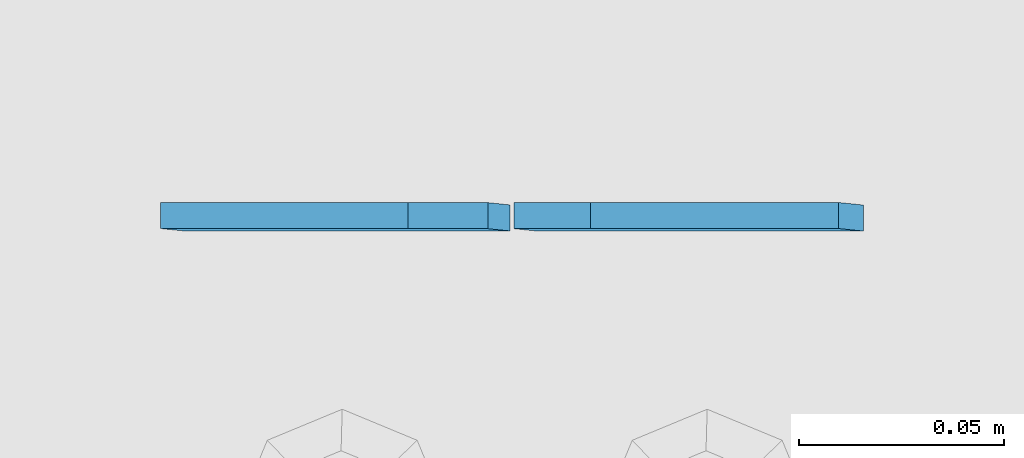
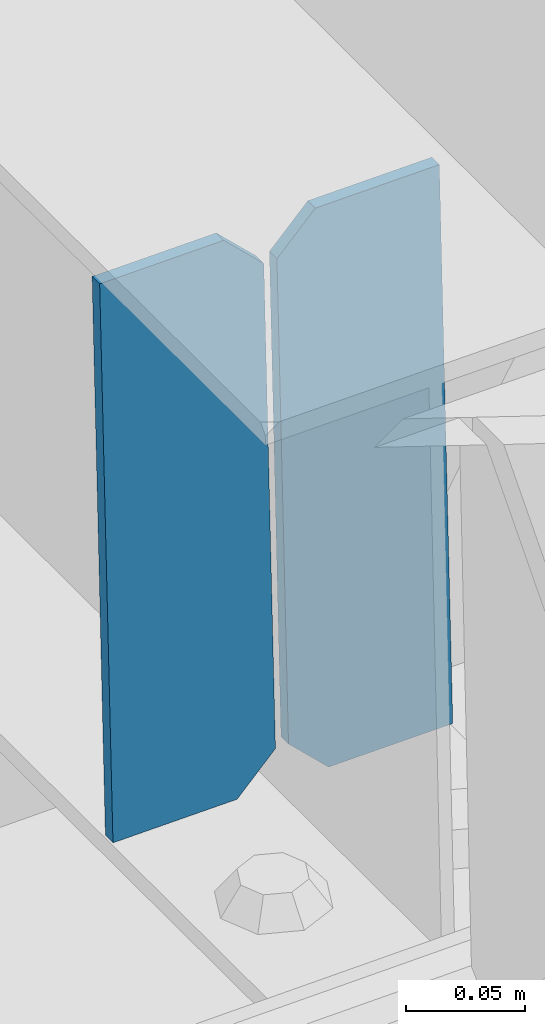
# One storey, part 3375 of 3843: 2 plates, 1 element without a shape of its own.
"""IFC2X3 building model written with IfcOpenShell, lengths in millimetres."""

from ifc_helpers import new_model, si_unit, frame, origin_with_axes, place, context, subcontext, project, spatial, faceted_brep, material, type_object, element, aggregate, save


model = new_model("IFC2X3")

# Units and contexts
model_context = context("Model", 3, precision=1e-05, world=origin_with_axes())
body_context = subcontext(model_context, "Body", "Model", "MODEL_VIEW")
ifc_project = project(units=[si_unit("LENGTHUNIT", "METRE", prefix="MILLI"), si_unit("AREAUNIT", "SQUARE_METRE"), si_unit("VOLUMEUNIT", "CUBIC_METRE"), si_unit("MASSUNIT", "GRAM", prefix="KILO"), si_unit("TIMEUNIT", "SECOND"), si_unit("PLANEANGLEUNIT", "RADIAN"), si_unit("SOLIDANGLEUNIT", "STERADIAN"), si_unit("THERMODYNAMICTEMPERATUREUNIT", "DEGREE_CELSIUS"), si_unit("LUMINOUSINTENSITYUNIT", "LUMEN")], contexts=[model_context])

# Site, building, storey
site_placement = place(None, origin_with_axes())
site = spatial("IfcSite", under=ifc_project, at=site_placement, CompositionType="ELEMENT")
building_placement = place(site_placement, origin_with_axes())
building = spatial("IfcBuilding", under=site, at=building_placement, Name="Undefined", CompositionType="ELEMENT")
storey_placement = place(building_placement, origin_with_axes())
storey = spatial("IfcBuildingStorey", under=building, at=storey_placement, Name="Undefined", CompositionType="ELEMENT", Elevation=0.0)

# Assembly, plates
assembly_placement = place(storey_placement, origin_with_axes())
assembly = element("IfcElementAssembly", 1, at=assembly_placement, inside=storey, Name="BEAM", AssemblyPlace="NOTDEFINED", PredefinedType="RIGID_FRAME")
ifc_material = material(Name="STEEL/A572-50")
plate_type = type_object("IfcPlateType", PredefinedType="NOTDEFINED")
plate_1_placement = place(assembly_placement, frame((40773.0964783088, 75783.4289593356, 45538.0196245364), z_axis=(-0.0211520975252424, 0.00216334199957782, 0.999773928806746), x_axis=(-0.999776269356297, -4.57939999836346e-05, -0.021152048007558)))
plate_1 = element("IfcPlate", 2, at=plate_1_placement, type_object=plate_type, material=ifc_material, Name="PLATE", context=body_context, shape_type="Brep", body=[
    faceted_brep([(0.0, -3.17499999999927, 0.0), (6.83940015733242e-10, -3.17499999996653, 288.924999998613), (6.54836185276508e-10, 3.17500000001746, 288.924999998591), (0.0, 3.17499999999927, 0.0), (60.3250007643655, -3.17500000017753, 288.924999998606), (60.3250007643219, 3.17499999979918, 288.924999998584), (79.3750000013097, -3.17500000025029, 269.875000761494), (79.375000001266, 3.17499999972642, 269.875000761487), (79.375000000713, -3.17500000026484, 19.0499992370605), (79.3750000006985, 3.17499999971187, 19.0499992370533), (60.325000763667, -3.17500000020664, -1.45519152283669e-11), (60.3250007636234, 3.17499999977736, -3.63797880709171e-11)], [[[0, 1, 2, 3]], [[1, 4, 5, 2]], [[4, 6, 7, 5]], [[6, 8, 9, 7]], [[8, 10, 11, 9]], [[10, 0, 3, 11]], [[5, 7, 9, 11, 3, 2]], [[10, 8, 6, 4, 1, 0]]]),
])
plate_2_placement = place(assembly_placement, frame((40687.3906576195, 75783.4250357465, 45536.2063651812), z_axis=(-0.0211520975252424, 0.00216334199957782, 0.999773928806746), x_axis=(-0.999776269356297, -4.57939999836346e-05, -0.021152048007558)))
plate_2 = element("IfcPlate", 3, at=plate_2_placement, type_object=plate_type, material=ifc_material, Name="PLATE", context=body_context, shape_type="Brep", body=[
    faceted_brep([(4.36557456851006e-11, -3.17499999998836, 19.0499992370969), (6.11180439591408e-10, -3.17499999996653, 269.875000761516), (5.96628524363041e-10, 3.17500000001746, 269.875000761502), (1.45519152283669e-11, 3.17499999998836, 19.0499992370824), (19.0499992376572, -3.17500000003201, 288.924999998606), (19.0499992376281, 3.1749999999447, 288.924999998584), (79.3750000013242, -3.17500000025029, 288.924999998591), (79.3750000013097, 3.1749999997337, 288.92499999857), (79.3750000006548, -3.17500000026484, -2.18278728425503e-11), (79.3750000006403, 3.17499999969732, -2.91038304567337e-11), (19.0499992370023, -3.17500000005384, 0.0), (19.0499992369587, 3.17499999992287, -1.45519152283669e-11)], [[[0, 1, 2, 3]], [[1, 4, 5, 2]], [[4, 6, 7, 5]], [[6, 8, 9, 7]], [[8, 10, 11, 9]], [[10, 0, 3, 11]], [[5, 7, 9, 11, 3, 2]], [[10, 8, 6, 4, 1, 0]]]),
])
aggregate(assembly, [plate_1, plate_2])

save(model, "model.ifc")
